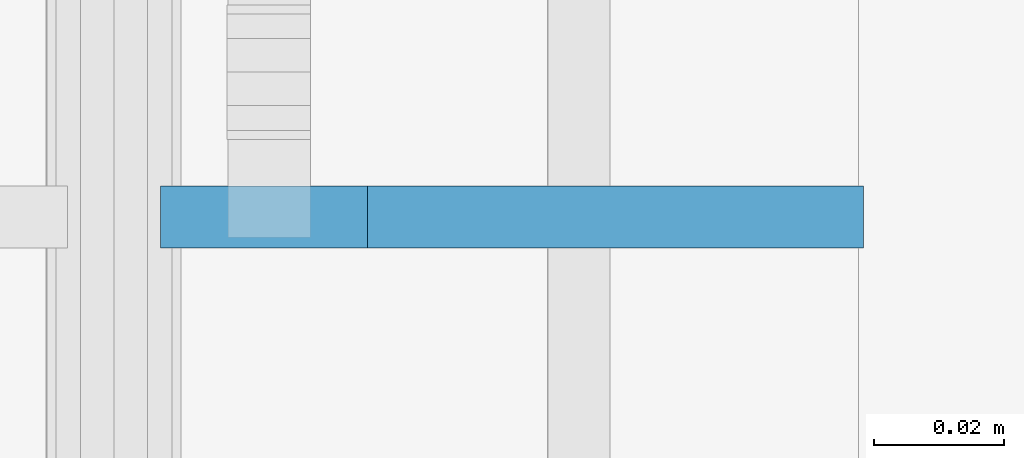
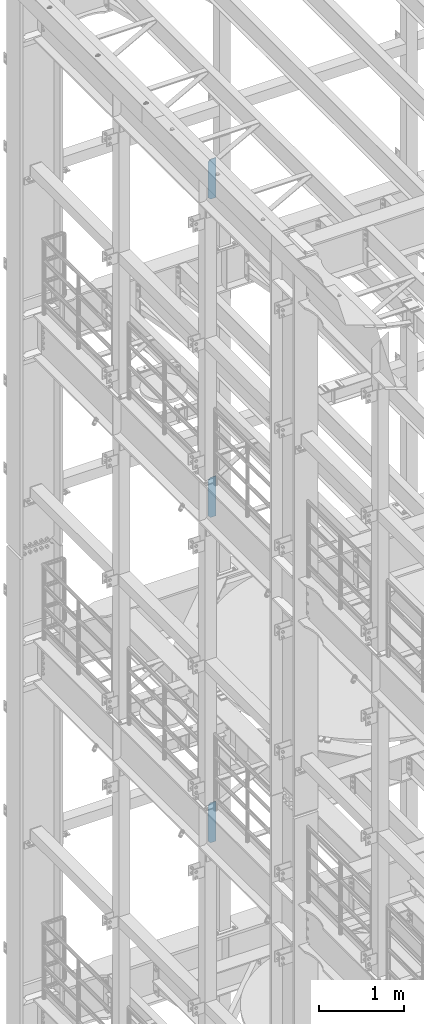
# One storey, part 1709 of 1876: 3 plates, 3 elements without a shape of their own.
"""IFC2X3 building model written with IfcOpenShell, lengths in millimetres."""

from ifc_helpers import new_model, si_unit, frame, origin_with_axes, place, context, subcontext, project, spatial, faceted_brep, material, type_object, element, aggregate, save


model = new_model("IFC2X3")

# Units and contexts
model_context = context("Model", 3, precision=1e-05, world=origin_with_axes())
body_context = subcontext(model_context, "Body", "Model", "MODEL_VIEW")
ifc_project = project(units=[si_unit("LENGTHUNIT", "METRE", prefix="MILLI"), si_unit("AREAUNIT", "SQUARE_METRE"), si_unit("VOLUMEUNIT", "CUBIC_METRE"), si_unit("MASSUNIT", "GRAM", prefix="KILO"), si_unit("TIMEUNIT", "SECOND"), si_unit("PLANEANGLEUNIT", "RADIAN"), si_unit("SOLIDANGLEUNIT", "STERADIAN"), si_unit("THERMODYNAMICTEMPERATUREUNIT", "DEGREE_CELSIUS"), si_unit("LUMINOUSINTENSITYUNIT", "LUMEN")], contexts=[model_context])

# Site, building, storey
site_placement = place(None, origin_with_axes())
site = spatial("IfcSite", under=ifc_project, at=site_placement, CompositionType="ELEMENT")
building_placement = place(site_placement, origin_with_axes())
building = spatial("IfcBuilding", under=site, at=building_placement, Name="Undefined", CompositionType="ELEMENT")
storey_placement = place(building_placement, origin_with_axes())
storey = spatial("IfcBuildingStorey", under=building, at=storey_placement, Name="Undefined", CompositionType="ELEMENT", Elevation=0.0)

# Assembly, plate
assembly_1_placement = place(storey_placement, origin_with_axes())
assembly_1 = element("IfcElementAssembly", 1, at=assembly_1_placement, inside=storey, Name="BEAM", AssemblyPlace="NOTDEFINED", PredefinedType="RIGID_FRAME")
ifc_material = material(Name="STEEL/A36")
plate_type = type_object("IfcPlateType", PredefinedType="NOTDEFINED")
plate_1_placement = place(assembly_1_placement, frame((115.093746948242, 9652.0000004947, 21958.3), z_axis=(0.0, 0.0, 1.0), x_axis=(-1.0, 0.0, 0.0)))
plate_1 = element("IfcPlate", 2, at=plate_1_placement, type_object=plate_type, material=ifc_material, Name="PLATE", context=body_context, shape_type="Brep", body=[
    faceted_brep([(0.0, -4.76249999999982, 0.0), (0.0, -4.76249999999982, 571.5), (0.0, 4.76249999999982, 571.5), (0.0, 4.76249999999982, 0.0), (76.1999969482422, -4.76249999999982, 571.5), (76.1999969482422, 4.76249999999982, 571.5), (107.949996948242, -4.76249999999982, 539.75), (107.949996948242, 4.76249999999982, 539.75), (107.949996948242, -4.76249999999982, 31.75), (107.949996948242, 4.76249999999982, 31.75), (76.1999969482422, -4.76250000000073, 0.0), (76.1999969482422, 4.76250000000073, 0.0)], [[[0, 1, 2, 3]], [[1, 4, 5, 2]], [[4, 6, 7, 5]], [[6, 8, 9, 7]], [[8, 10, 11, 9]], [[10, 0, 3, 11]], [[5, 7, 9, 11, 3, 2]], [[10, 8, 6, 4, 1, 0]]]),
])
aggregate(assembly_1, [plate_1])

assembly_2_placement = place(storey_placement, origin_with_axes())
assembly_2 = element("IfcElementAssembly", 3, at=assembly_2_placement, inside=storey, Name="BEAM", AssemblyPlace="NOTDEFINED", PredefinedType="RIGID_FRAME")
plate_2_placement = place(assembly_2_placement, frame((115.093754918769, 9652.00000025619, 17386.3), z_axis=(0.0, 0.0, 1.0), x_axis=(-1.0, 0.0, 0.0)))
plate_2 = element("IfcPlate", 4, at=plate_2_placement, type_object=plate_type, material=ifc_material, Name="PLATE", context=body_context, shape_type="Brep", body=[
    faceted_brep([(0.0, -4.76249999999982, 0.0), (0.0, -4.76249999999982, 571.5), (0.0, 4.76249999999982, 571.5), (0.0, 4.76249999999982, 0.0), (76.1999969482422, -4.76249999999982, 571.5), (76.1999969482422, 4.76249999999982, 571.5), (107.949996948242, -4.76249999999982, 539.75), (107.949996948242, 4.76249999999982, 539.75), (107.949996948242, -4.76249999999982, 31.75), (107.949996948242, 4.76249999999982, 31.75), (76.1999969482422, -4.76250000000073, 0.0), (76.1999969482422, 4.76250000000073, 0.0)], [[[0, 1, 2, 3]], [[1, 4, 5, 2]], [[4, 6, 7, 5]], [[6, 8, 9, 7]], [[8, 10, 11, 9]], [[10, 0, 3, 11]], [[5, 7, 9, 11, 3, 2]], [[10, 8, 6, 4, 1, 0]]]),
])
aggregate(assembly_2, [plate_2])

assembly_3_placement = place(storey_placement, origin_with_axes())
assembly_3 = element("IfcElementAssembly", 5, at=assembly_3_placement, inside=storey, Name="BEAM", AssemblyPlace="NOTDEFINED", PredefinedType="RIGID_FRAME")
plate_3_placement = place(assembly_3_placement, frame((115.093727780733, 9652.00000025619, 12712.7), z_axis=(0.0, 0.0, 1.0), x_axis=(-1.0, 0.0, 0.0)))
plate_3 = element("IfcPlate", 6, at=plate_3_placement, type_object=plate_type, material=ifc_material, Name="PLATE", context=body_context, shape_type="Brep", body=[
    faceted_brep([(0.0, -4.76249999999982, 0.0), (0.0, -4.76249999999982, 571.5), (0.0, 4.76249999999982, 571.5), (0.0, 4.76249999999982, 0.0), (76.1999969482422, -4.76249999999982, 571.5), (76.1999969482422, 4.76249999999982, 571.5), (107.949996948242, -4.76249999999982, 539.75), (107.949996948242, 4.76249999999982, 539.75), (107.949996948242, -4.76249999999982, 31.75), (107.949996948242, 4.76249999999982, 31.75), (76.1999969482422, -4.76250000000073, 0.0), (76.1999969482422, 4.76250000000073, 0.0)], [[[0, 1, 2, 3]], [[1, 4, 5, 2]], [[4, 6, 7, 5]], [[6, 8, 9, 7]], [[8, 10, 11, 9]], [[10, 0, 3, 11]], [[5, 7, 9, 11, 3, 2]], [[10, 8, 6, 4, 1, 0]]]),
])
aggregate(assembly_3, [plate_3])

save(model, "model.ifc")
